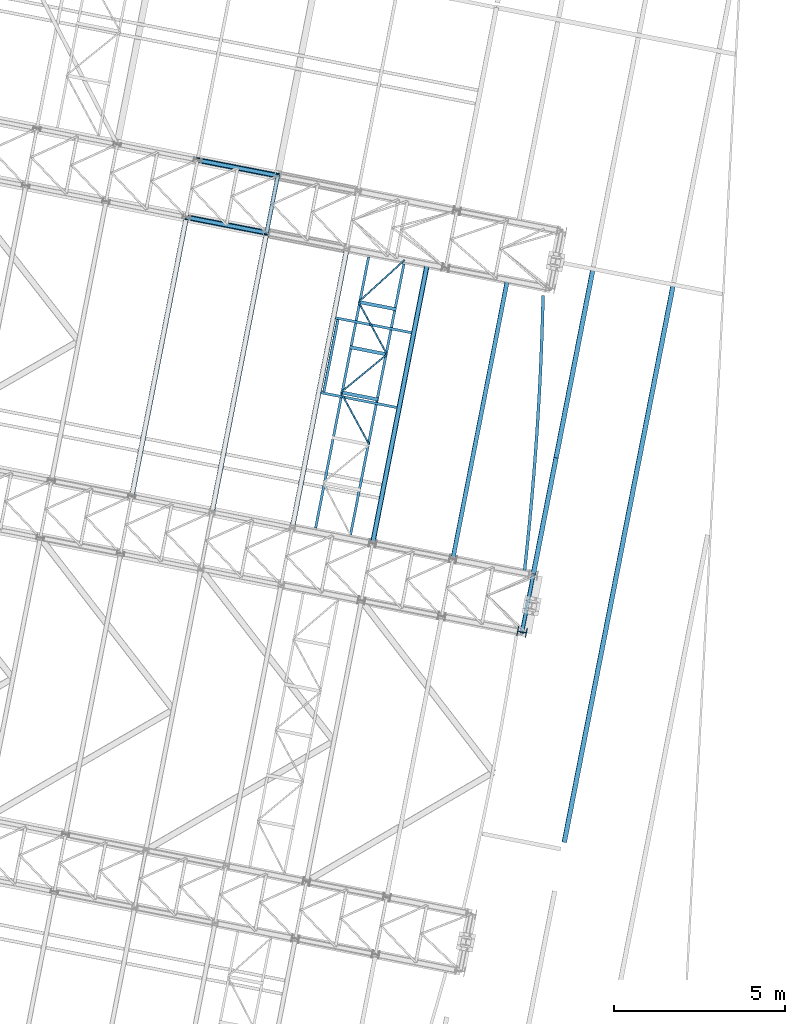
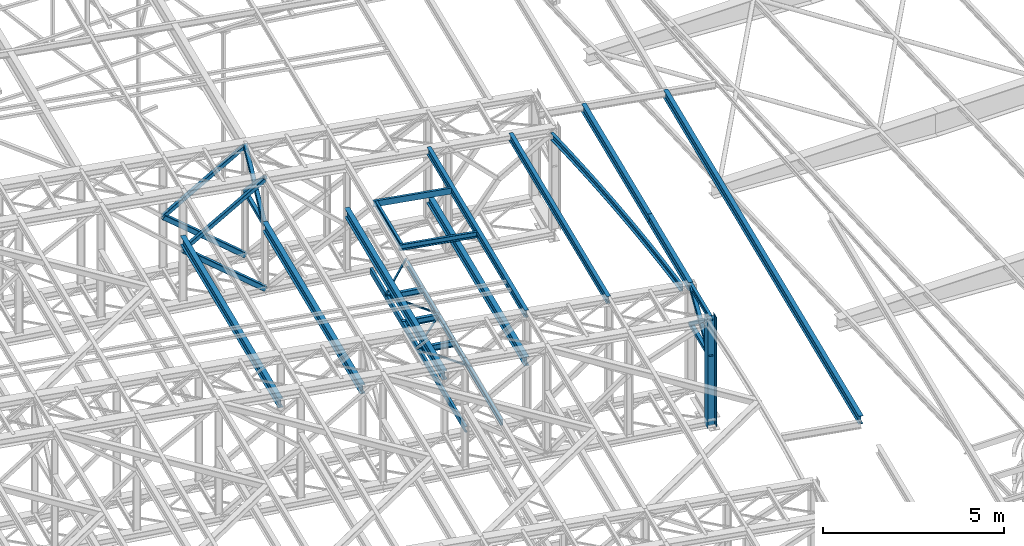
# One storey, part 92 of 215: 26 beams, 8 members, 34 elements without a shape of their own.
"""IFC2X3 building model written with IfcOpenShell, lengths in millimetres."""

from ifc_helpers import new_model, entity, si_unit, frame, origin_with_axes, origin_2d_with_axis, place, context, subcontext, project, spatial, hollow_rectangle, i_section, u_section, extrude, material, type_object, element, aggregate, save


model = new_model("IFC2X3")

# Units and contexts
model_context = context("Model", 3, precision=1e-05, world=origin_with_axes())
body_context = subcontext(model_context, "Body", "Model", "MODEL_VIEW")
ifc_project = project(units=[si_unit("LENGTHUNIT", "METRE", prefix="MILLI"), si_unit("AREAUNIT", "SQUARE_METRE"), si_unit("VOLUMEUNIT", "CUBIC_METRE"), si_unit("MASSUNIT", "GRAM", prefix="KILO"), si_unit("TIMEUNIT", "SECOND"), si_unit("PLANEANGLEUNIT", "RADIAN"), si_unit("SOLIDANGLEUNIT", "STERADIAN"), si_unit("THERMODYNAMICTEMPERATUREUNIT", "DEGREE_CELSIUS"), si_unit("LUMINOUSINTENSITYUNIT", "LUMEN")], contexts=[model_context])

# Site, building, storey
site_placement = place(None, origin_with_axes())
site = spatial("IfcSite", under=ifc_project, at=site_placement, CompositionType="ELEMENT")
building_placement = place(site_placement, origin_with_axes())
building = spatial("IfcBuilding", under=site, at=building_placement, Name="Undefined", CompositionType="ELEMENT")
storey_placement = place(building_placement, origin_with_axes())
storey = spatial("IfcBuildingStorey", under=building, at=storey_placement, Name="Undefined", CompositionType="ELEMENT", Elevation=0.0)

# Assembly, beam
assembly_1_placement = place(storey_placement, origin_with_axes())
assembly_1 = element("IfcElementAssembly", 1, at=assembly_1_placement, inside=storey, Name="Steel Assembly", AssemblyPlace="NOTDEFINED", PredefinedType="RIGID_FRAME")
ifc_material_1 = material(Name="STEEL/S275JR")
beam_type_1 = type_object("IfcBeamType", Name="IPE240", PredefinedType="NOTDEFINED")
beam_1_placement = place(assembly_1_placement, frame((92464.7736029224, 34669.0166630086, 12133.5284038221), z_axis=(0.0304080349965938, -0.00594450399933318, 0.999519891888024), x_axis=(0.191879342079262, 0.981418523405397, 1.00000006478113e-09)))
beam_1 = element("IfcBeam", 2, at=beam_1_placement, type_object=beam_type_1, material=ifc_material_1, ObjectType="IPE240", context=body_context, shape_type="SweptSolid", body=[
    extrude(i_section(OverallWidth=120.0, OverallDepth=240.0, WebThickness=6.199999809, FlangeThickness=9.800000191, FilletRadius=15.0, at=origin_2d_with_axis()), frame((8306.35394615426, -2.30547635042662e-13, -1.81898940354586e-12), z_axis=(-1.0, 0.0, 0.0), x_axis=(-6.93889390390723e-18, -1.0, -3.46944695195361e-18)), (0.0, 0.0, 1.0), 8306.4),
])
aggregate(assembly_1, [beam_1])

assembly_2_placement = place(storey_placement, origin_with_axes())
assembly_2 = element("IfcElementAssembly", 3, at=assembly_2_placement, inside=storey, Name="Steel Assembly", AssemblyPlace="NOTDEFINED", PredefinedType="RIGID_FRAME")
beam_2_placement = place(assembly_2_placement, frame((90120.7257215296, 35127.2574103357, 12207.5658521995), z_axis=(0.0304080349965938, -0.00594450399933318, 0.999519891888024), x_axis=(0.191879342079262, 0.981418523405397, 1.00000006478113e-09)))
beam_2 = element("IfcBeam", 4, at=beam_2_placement, type_object=beam_type_1, material=ifc_material_1, ObjectType="IPE240", context=body_context, shape_type="SweptSolid", body=[
    extrude(i_section(OverallWidth=120.0, OverallDepth=240.0, WebThickness=6.199999809, FlangeThickness=9.800000191, FilletRadius=15.0, at=origin_2d_with_axis()), frame((8306.35394615426, -2.30547635042662e-13, -1.81898940354586e-12), z_axis=(-1.0, 0.0, 0.0), x_axis=(-6.93889390390723e-18, -1.0, -3.46944695195361e-18)), (0.0, 0.0, 1.0), 8306.4),
])
aggregate(assembly_2, [beam_2])

assembly_3_placement = place(storey_placement, origin_with_axes())
assembly_3 = element("IfcElementAssembly", 5, at=assembly_3_placement, inside=storey, Name="Steel Assembly", AssemblyPlace="NOTDEFINED", PredefinedType="RIGID_FRAME")
beam_type_2 = type_object("IfcBeamType", Name="IPE270", PredefinedType="NOTDEFINED")
beam_3_placement = place(assembly_3_placement, frame((95717.9008817921, 26398.0012598187, 11970.3617768862), z_axis=(0.0304080349965938, -0.00594450399933318, 0.999519891888024), x_axis=(0.191856902084618, 0.981422910432851, 8.10000000298011e-08)))
beam_3 = element("IfcBeam", 6, at=beam_3_placement, type_object=beam_type_2, material=ifc_material_1, ObjectType="IPE270", context=body_context, shape_type="SweptSolid", body=[
    extrude(i_section(OverallWidth=135.0, OverallDepth=270.0, WebThickness=6.599999905, FlangeThickness=10.19999981, FilletRadius=15.0, at=origin_2d_with_axis()), frame((16594.88763763, -1.46841138771197e-11, 1.79283458527974e-12), z_axis=(-1.0, 0.0, 0.0), x_axis=(-6.93889390390723e-18, -1.0, -3.46944695195361e-18)), (0.0, 0.0, 1.0), 16594.9),
])
aggregate(assembly_3, [beam_3])

assembly_4_placement = place(storey_placement, origin_with_axes())
assembly_4 = element("IfcElementAssembly", 7, at=assembly_4_placement, inside=storey, Name="Steel Assembly", AssemblyPlace="NOTDEFINED", PredefinedType="RIGID_FRAME")
beam_4_placement = place(assembly_4_placement, frame((94811.4975987775, 34210.2529990498, 12044.3992257007), z_axis=(0.0304080349965938, -0.00594450399933318, 0.999519891888024), x_axis=(0.191859470081235, 0.981422408415534, 0.0)))
beam_4 = element("IfcBeam", 8, at=beam_4_placement, type_object=beam_type_2, material=ifc_material_1, ObjectType="IPE270", context=body_context, shape_type="SweptSolid", body=[
    extrude(i_section(OverallWidth=135.0, OverallDepth=270.0, WebThickness=6.599999905, FlangeThickness=10.19999981, FilletRadius=15.0, at=origin_2d_with_axis()), frame((3479.26394301375, 0.0, 0.0), z_axis=(-1.0, 0.0, 0.0), x_axis=(-6.93889390390723e-18, -1.0, -3.46944695195361e-18)), (0.0, 0.0, 1.0), 3479.3),
])
aggregate(assembly_4, [beam_4])

assembly_5_placement = place(storey_placement, origin_with_axes())
assembly_5 = element("IfcElementAssembly", 9, at=assembly_5_placement, inside=storey, Name="Steel Assembly", AssemblyPlace="NOTDEFINED", PredefinedType="RIGID_FRAME")
beam_5_placement = place(assembly_5_placement, frame((95479.0273205774, 37624.8806002424, 12044.3992256195), z_axis=(0.0304080349965938, -0.00594450399933318, 0.999519891888024), x_axis=(0.191851899087581, 0.98142388844802, 2.39000000165156e-07)))
beam_5 = element("IfcBeam", 10, at=beam_5_placement, type_object=beam_type_2, material=ifc_material_1, ObjectType="IPE270", context=body_context, shape_type="SweptSolid", body=[
    extrude(i_section(OverallWidth=135.0, OverallDepth=270.0, WebThickness=6.599999905, FlangeThickness=10.19999981, FilletRadius=15.0, at=origin_2d_with_axis()), frame((5622.40682280192, 9.98296796440295e-14, -1.81760682979885e-12), z_axis=(-1.0, 0.0, 0.0), x_axis=(-6.93889390390723e-18, -1.0, -3.46944695195361e-18)), (0.0, 0.0, 1.0), 5622.4),
])
aggregate(assembly_5, [beam_5])

assembly_6_placement = place(storey_placement, origin_with_axes())
assembly_6 = element("IfcElementAssembly", 11, at=assembly_6_placement, inside=storey, Name="Steel Assembly", AssemblyPlace="NOTDEFINED", PredefinedType="RIGID_FRAME")
beam_type_3 = type_object("IfcBeamType", PredefinedType="NOTDEFINED")
beam_6_placement = place(assembly_6_placement, frame((87029.9324652651, 44195.0674298513, 10796.000000583), z_axis=(0.981422364268518, -0.191859461052493, -0.000300197000082615), x_axis=(0.191859470081235, 0.981422408415534, 0.0)))
beam_6 = element("IfcBeam", 12, at=beam_6_placement, type_object=beam_type_3, material=ifc_material_1, context=body_context, shape_type="SweptSolid", body=[
    extrude(hollow_rectangle(XDim=120.0, YDim=120.0, WallThickness=5.0, InnerFilletRadius=5.0, OuterFilletRadius=10.0, at=origin_2d_with_axis()), frame((1699.99999941724, 1.81898940354586e-12, 0.0), z_axis=(-1.0, 0.0, 0.0), x_axis=(-6.93889390390723e-18, -1.0, -3.46944695195361e-18)), (0.0, 0.0, 1.0), 1700.0),
])
aggregate(assembly_6, [beam_6])

assembly_7_placement = place(storey_placement, origin_with_axes())
assembly_7 = element("IfcElementAssembly", 13, at=assembly_7_placement, inside=storey, Name="Steel Assembly", AssemblyPlace="NOTDEFINED", PredefinedType="RIGID_FRAME")
beam_7_placement = place(assembly_7_placement, frame((94486.3047201843, 32541.6453840802, 10796.000000571), z_axis=(0.981422364268518, -0.191859461052493, -0.000300197000082615), x_axis=(0.191859470081235, 0.981422408415534, 0.0)))
beam_7 = element("IfcBeam", 14, at=beam_7_placement, type_object=beam_type_3, material=ifc_material_1, context=body_context, shape_type="SweptSolid", body=[
    extrude(hollow_rectangle(XDim=120.0, YDim=120.0, WallThickness=5.0, InnerFilletRadius=5.0, OuterFilletRadius=10.0, at=origin_2d_with_axis()), frame((1699.99999941724, 1.81898940354586e-12, 0.0), z_axis=(-1.0, 0.0, 0.0), x_axis=(-6.93889390390723e-18, -1.0, -3.46944695195361e-18)), (0.0, 0.0, 1.0), 1700.0),
])
aggregate(assembly_7, [beam_7])

assembly_8_placement = place(storey_placement, origin_with_axes())
assembly_8 = element("IfcElementAssembly", 15, at=assembly_8_placement, inside=storey, Name="Steel Assembly", AssemblyPlace="NOTDEFINED", PredefinedType="RIGID_FRAME")
beam_type_4 = type_object("IfcBeamType", PredefinedType="NOTDEFINED")
beam_8_placement = place(assembly_8_placement, frame((89196.8303860117, 39539.664538878, 8705.0), z_axis=(0.0, 0.0, -1.0), x_axis=(0.47673765088779, -0.879045625793105, 0.0)))
beam_8 = element("IfcBeam", 16, at=beam_8_placement, type_object=beam_type_4, material=ifc_material_1, context=body_context, shape_type="SweptSolid", body=[
    extrude(hollow_rectangle(XDim=50.0, YDim=50.0, WallThickness=3.0, InnerFilletRadius=3.0, OuterFilletRadius=6.0, at=origin_2d_with_axis()), frame((1742.75933422754, 0.0, 1.81898940354586e-12), z_axis=(-1.0, 0.0, 0.0), x_axis=(-6.93889390390723e-18, -1.0, -3.46944695195361e-18)), (0.0, 0.0, 1.0), 1742.8),
])
aggregate(assembly_8, [beam_8])

assembly_9_placement = place(storey_placement, origin_with_axes())
assembly_9 = element("IfcElementAssembly", 17, at=assembly_9_placement, inside=storey, Name="Steel Assembly", AssemblyPlace="NOTDEFINED", PredefinedType="RIGID_FRAME")
beam_9_placement = place(assembly_9_placement, frame((90543.5401901868, 40646.5326737359, 8705.0), z_axis=(0.0, 0.0, -1.0), x_axis=(-0.772545523248249, -0.634959380204033, 0.0)))
beam_9 = element("IfcBeam", 18, at=beam_9_placement, type_object=beam_type_4, material=ifc_material_1, context=body_context, shape_type="SweptSolid", body=[
    extrude(hollow_rectangle(XDim=50.0, YDim=50.0, WallThickness=3.0, InnerFilletRadius=3.0, OuterFilletRadius=6.0, at=origin_2d_with_axis()), frame((1743.21093515124, 0.0, 0.0), z_axis=(-1.0, 0.0, 0.0), x_axis=(-6.93889390390723e-18, -1.0, -3.46944695195361e-18)), (0.0, 0.0, 1.0), 1743.2),
])
aggregate(assembly_9, [beam_9])

assembly_10_placement = place(storey_placement, origin_with_axes())
assembly_10 = element("IfcElementAssembly", 19, at=assembly_10_placement, inside=storey, Name="Steel Assembly", AssemblyPlace="NOTDEFINED", PredefinedType="RIGID_FRAME")
beam_10_placement = place(assembly_10_placement, frame((89712.6980049492, 42178.4982678399, 8705.0), z_axis=(0.0, 0.0, -1.0), x_axis=(0.476738917056294, -0.879044939103794, 0.0)))
beam_10 = element("IfcBeam", 20, at=beam_10_placement, type_object=beam_type_4, material=ifc_material_1, context=body_context, shape_type="SweptSolid", body=[
    extrude(hollow_rectangle(XDim=50.0, YDim=50.0, WallThickness=3.0, InnerFilletRadius=3.0, OuterFilletRadius=6.0, at=origin_2d_with_axis()), frame((1742.76140598496, 0.0, 0.0), z_axis=(-1.0, 0.0, 0.0), x_axis=(-6.93889390390723e-18, -1.0, -3.46944695195361e-18)), (0.0, 0.0, 1.0), 1742.8),
])
aggregate(assembly_10, [beam_10])

assembly_11_placement = place(storey_placement, origin_with_axes())
assembly_11 = element("IfcElementAssembly", 21, at=assembly_11_placement, inside=storey, Name="Steel Assembly", AssemblyPlace="NOTDEFINED", PredefinedType="RIGID_FRAME")
beam_11_placement = place(assembly_11_placement, frame((91061.8771984963, 43406.8577655462, 8705.0), z_axis=(0.0, 0.0, -1.0), x_axis=(-0.73943985096372, -0.673222627966969, 0.0)))
beam_11 = element("IfcBeam", 22, at=beam_11_placement, type_object=beam_type_4, material=ifc_material_1, context=body_context, shape_type="SweptSolid", body=[
    extrude(hollow_rectangle(XDim=50.0, YDim=50.0, WallThickness=3.0, InnerFilletRadius=3.0, OuterFilletRadius=6.0, at=origin_2d_with_axis()), frame((1824.59627101341, 0.0, 1.81898940354586e-12), z_axis=(-1.0, 0.0, 0.0), x_axis=(-6.93889390390723e-18, -1.0, -3.46944695195361e-18)), (0.0, 0.0, 1.0), 1824.6),
])
aggregate(assembly_11, [beam_11])

assembly_12_placement = place(storey_placement, origin_with_axes())
assembly_12 = element("IfcElementAssembly", 23, at=assembly_12_placement, inside=storey, Name="Steel Assembly", AssemblyPlace="NOTDEFINED", PredefinedType="RIGID_FRAME")
beam_type_5 = type_object("IfcBeamType", Name="IPE180", PredefinedType="NOTDEFINED")
beam_12_placement = place(assembly_12_placement, frame((94815.6026834551, 34209.4504909996, 12089.3344109517), z_axis=(0.0, 0.0, 1.0), x_axis=(-0.191859508000518, -0.981422401002646, -1.00000033853845e-09)))
beam_12 = element("IfcBeam", 24, at=beam_12_placement, type_object=beam_type_5, material=ifc_material_1, ObjectType="IPE180", context=body_context, shape_type="SweptSolid", body=[
    extrude(i_section(OverallWidth=91.0, OverallDepth=180.0, WebThickness=5.300000191, FlangeThickness=8.0, FilletRadius=9.0, at=origin_2d_with_axis()), frame((1699.99999941724, 1.81898940354586e-12, 0.0), z_axis=(-1.0, 0.0, 0.0), x_axis=(-6.93889390390723e-18, -1.0, -3.46944695195361e-18)), (0.0, 0.0, 1.0), 1700.0),
])
aggregate(assembly_12, [beam_12])

assembly_13_placement = place(storey_placement, origin_with_axes())
assembly_13 = element("IfcElementAssembly", 25, at=assembly_13_placement, inside=storey, Name="Steel Assembly", AssemblyPlace="NOTDEFINED", PredefinedType="RIGID_FRAME")
ifc_material_2 = material(Name="STEEL/S235JR")
beam_type_6 = type_object("IfcBeamType", Name="UPN200", PredefinedType="NOTDEFINED")
beam_13_placement = place(assembly_13_placement, frame((89110.6194647194, 41661.9895352668, 12297.155118531), z_axis=(0.0304080349965938, -0.00594450399933318, 0.999519891888024), x_axis=(-0.19187685493533, -0.98141900966922, -1.21999999765762e-07)))
beam_13 = element("IfcBeam", 26, at=beam_13_placement, type_object=beam_type_6, material=ifc_material_2, ObjectType="UPN200", context=body_context, shape_type="SweptSolid", body=[
    extrude(u_section(Depth=200.0, FlangeWidth=75.0, WebThickness=8.5, FlangeThickness=11.5, FilletRadius=11.5, EdgeRadius=6.0, FlangeSlope=0.0798299857122373, at=origin_2d_with_axis()), frame((2150.01524213469, 1.45109582611845e-11, -1.81736478151208e-12), z_axis=(-1.0, 0.0, 0.0), x_axis=(-6.93889390390723e-18, -1.0, -3.46944695195361e-18)), (0.0, 0.0, 1.0), 2150.0),
])
aggregate(assembly_13, [beam_13])

assembly_14_placement = place(storey_placement, origin_with_axes())
assembly_14 = element("IfcElementAssembly", 27, at=assembly_14_placement, inside=storey, Name="Steel Assembly", AssemblyPlace="NOTDEFINED", PredefinedType="RIGID_FRAME")
beam_14_placement = place(assembly_14_placement, frame((91263.0604896444, 41279.3433122917, 12229.4151626319), z_axis=(0.0304080349965938, -0.00594450399933318, 0.999519891888024), x_axis=(-0.980947274706054, 0.19178753394253, 0.030983641990716)))
beam_14 = element("IfcBeam", 28, at=beam_14_placement, type_object=beam_type_6, material=ifc_material_2, ObjectType="UPN200", context=body_context, shape_type="SweptSolid", body=[
    extrude(u_section(Depth=200.0, FlangeWidth=75.0, WebThickness=8.5, FlangeThickness=11.5, FilletRadius=11.5, EdgeRadius=6.0, FlangeSlope=0.0798299857122373, at=origin_2d_with_axis()), frame((2269.56619159897, -1.00164711038344e-14, -7.87413950570001e-15), z_axis=(-1.0, 0.0, 0.0), x_axis=(-6.93889390390723e-18, -1.0, -3.46944695195361e-18)), (0.0, 0.0, 1.0), 2269.6),
])
aggregate(assembly_14, [beam_14])

assembly_15_placement = place(storey_placement, origin_with_axes())
assembly_15 = element("IfcElementAssembly", 29, at=assembly_15_placement, inside=storey, Name="Steel Assembly", AssemblyPlace="NOTDEFINED", PredefinedType="RIGID_FRAME")
beam_15_placement = place(assembly_15_placement, frame((88609.8028451448, 39530.9733193749, 12299.7346048043), z_axis=(0.0304080349965938, -0.00594450399933318, 0.999519891888024), x_axis=(0.980947274706054, -0.191787533942531, -0.0309836419907153)))
beam_15 = element("IfcBeam", 30, at=beam_15_placement, type_object=beam_type_6, material=ifc_material_2, ObjectType="UPN200", context=body_context, shape_type="SweptSolid", body=[
    extrude(u_section(Depth=200.0, FlangeWidth=75.0, WebThickness=8.5, FlangeThickness=11.5, FilletRadius=11.5, EdgeRadius=6.0, FlangeSlope=0.0798299857122373, at=origin_2d_with_axis()), frame((2269.56619159897, -1.00164711038344e-14, -7.87413950570001e-15), z_axis=(-1.0, 0.0, 0.0), x_axis=(-6.93889390390723e-18, -1.0, -3.46944695195361e-18)), (0.0, 0.0, 1.0), 2269.6),
])
aggregate(assembly_15, [beam_15])

assembly_16_placement = place(storey_placement, origin_with_axes())
assembly_16 = element("IfcElementAssembly", 31, at=assembly_16_placement, inside=storey, Name="Steel Assembly", AssemblyPlace="NOTDEFINED", PredefinedType="RIGID_FRAME")
beam_16_placement = place(assembly_16_placement, frame((90007.4367460947, 43490.7200616785, 8630.00000003358), z_axis=(0.0, 0.0, -1.0), x_axis=(-0.191860814904866, -0.981422145513357, 0.0)))
beam_16 = element("IfcBeam", 32, at=beam_16_placement, type_object=beam_type_6, material=ifc_material_1, ObjectType="UPN200", context=body_context, shape_type="SweptSolid", body=[
    extrude(u_section(Depth=200.0, FlangeWidth=75.0, WebThickness=8.5, FlangeThickness=11.5, FilletRadius=11.5, EdgeRadius=6.0, FlangeSlope=0.0798299857122373, at=origin_2d_with_axis()), frame((8066.3539238149, -1.45519152283669e-11, 0.0), z_axis=(-1.0, 0.0, 0.0), x_axis=(-6.93889390390723e-18, -1.0, -3.46944695195361e-18)), (0.0, 0.0, 1.0), 8066.4),
])
aggregate(assembly_16, [beam_16])

assembly_17_placement = place(storey_placement, origin_with_axes())
assembly_17 = element("IfcElementAssembly", 33, at=assembly_17_placement, inside=storey, Name="Steel Assembly", AssemblyPlace="NOTDEFINED", PredefinedType="RIGID_FRAME")
beam_17_placement = place(assembly_17_placement, frame((89478.2340234499, 35375.1935051525, 8630.00000000009), z_axis=(0.0, 0.0, -1.0), x_axis=(0.193474000916928, 0.981105402578743, 0.0)))
beam_17 = element("IfcBeam", 34, at=beam_17_placement, type_object=beam_type_6, material=ifc_material_1, ObjectType="UPN200", context=body_context, shape_type="SweptSolid", body=[
    extrude(u_section(Depth=200.0, FlangeWidth=75.0, WebThickness=8.5, FlangeThickness=11.5, FilletRadius=11.5, EdgeRadius=6.0, FlangeSlope=0.0798299857122373, at=origin_2d_with_axis()), frame((8066.36484263777, 0.0, 0.0), z_axis=(-1.0, 0.0, 0.0), x_axis=(-6.93889390390723e-18, -1.0, -3.46944695195361e-18)), (0.0, 0.0, 1.0), 8066.4),
])
aggregate(assembly_17, [beam_17])

# Assembly, member
assembly_18_placement = place(storey_placement, origin_with_axes())
assembly_18 = element("IfcElementAssembly", 35, at=assembly_18_placement, inside=storey, Name="Steel Assembly", AssemblyPlace="NOTDEFINED", PredefinedType="RIGID_FRAME")
member_type_1 = type_object("IfcMemberType", PredefinedType="NOTDEFINED")
member_1_placement = place(assembly_18_placement, frame((87356.093563519, 45863.4855236941, 10796.0000007861), z_axis=(0.981461701624211, -0.19165823792662, 0.000219270999915979), x_axis=(-0.140138869039808, -0.716855033203644, 0.682993381194025)))
member_1 = element("IfcMember", 36, at=member_1_placement, type_object=member_type_1, material=ifc_material_1, context=body_context, shape_type="SweptSolid", body=[
    extrude(hollow_rectangle(XDim=120.0, YDim=120.0, WallThickness=5.0, InnerFilletRadius=5.0, OuterFilletRadius=10.0, at=origin_2d_with_axis()), frame((2327.41350452431, -7.27595761418343e-12, -1.06739260704213e-13), z_axis=(-1.0, 0.0, 0.0), x_axis=(-6.93889390390723e-18, -1.0, -3.46944695195361e-18)), (0.0, 0.0, 1.0), 2327.4),
])
aggregate(assembly_18, [member_1])

assembly_19_placement = place(storey_placement, origin_with_axes())
assembly_19 = element("IfcElementAssembly", 37, at=assembly_19_placement, inside=storey, Name="Steel Assembly", AssemblyPlace="NOTDEFINED", PredefinedType="RIGID_FRAME")
member_2_placement = place(assembly_19_placement, frame((87029.9324652651, 44195.0674298513, 10796.000000583), z_axis=(0.981461701624211, -0.19165823792662, -0.000219270999915979), x_axis=(0.140138870001192, 0.716855037006089, 0.682993377005801)))
member_2 = element("IfcMember", 38, at=member_2_placement, type_object=member_type_1, material=ifc_material_1, context=body_context, shape_type="SweptSolid", body=[
    extrude(hollow_rectangle(XDim=120.0, YDim=120.0, WallThickness=5.0, InnerFilletRadius=5.0, OuterFilletRadius=10.0, at=origin_2d_with_axis()), frame((2327.41350452431, -7.27595761418343e-12, -1.06739260704213e-13), z_axis=(-1.0, 0.0, 0.0), x_axis=(-6.93889390390723e-18, -1.0, -3.46944695195361e-18)), (0.0, 0.0, 1.0), 2327.4),
])
aggregate(assembly_19, [member_2])

assembly_20_placement = place(storey_placement, origin_with_axes())
assembly_20 = element("IfcElementAssembly", 39, at=assembly_20_placement, inside=storey, Name="Steel Assembly", AssemblyPlace="NOTDEFINED", PredefinedType="RIGID_FRAME")
member_3_placement = place(assembly_20_placement, frame((94812.4658186527, 34210.0634777308, 10796.0000009211), z_axis=(0.981457237582708, -0.191681072918501, 0.000238916999899001), x_axis=(-0.152693340951056, -0.781075161749645, 0.605480251805928)))
member_3 = element("IfcMember", 40, at=member_3_placement, type_object=member_type_1, material=ifc_material_1, context=body_context, shape_type="SweptSolid", body=[
    extrude(hollow_rectangle(XDim=120.0, YDim=120.0, WallThickness=5.0, InnerFilletRadius=5.0, OuterFilletRadius=10.0, at=origin_2d_with_axis()), frame((2136.05318296857, 7.27595761418343e-12, -1.45865960330521e-11), z_axis=(-1.0, 0.0, 0.0), x_axis=(-6.93889390390723e-18, -1.0, -3.46944695195361e-18)), (0.0, 0.0, 1.0), 2136.1),
])
aggregate(assembly_20, [member_3])

assembly_21_placement = place(storey_placement, origin_with_axes())
assembly_21 = element("IfcElementAssembly", 41, at=assembly_21_placement, inside=storey, Name="Steel Assembly", AssemblyPlace="NOTDEFINED", PredefinedType="RIGID_FRAME")
member_4_placement = place(assembly_21_placement, frame((94486.3047201843, 32541.6453840802, 10796.000000571), z_axis=(0.981457237582473, -0.191681072918455, -0.000238917999897463), x_axis=(0.15269334193976, 0.781075164691848, 0.605480247761123)))
member_4 = element("IfcMember", 42, at=member_4_placement, type_object=member_type_1, material=ifc_material_1, context=body_context, shape_type="SweptSolid", body=[
    extrude(hollow_rectangle(XDim=120.0, YDim=120.0, WallThickness=5.0, InnerFilletRadius=5.0, OuterFilletRadius=10.0, at=origin_2d_with_axis()), frame((2136.05318296857, 7.27595761418343e-12, -1.45865960330521e-11), z_axis=(-1.0, 0.0, 0.0), x_axis=(-6.93889390390723e-18, -1.0, -3.46944695195361e-18)), (0.0, 0.0, 1.0), 2136.1),
])
aggregate(assembly_21, [member_4])

assembly_22_placement = place(storey_placement, origin_with_axes())
assembly_22 = element("IfcElementAssembly", 43, at=assembly_22_placement, inside=storey, Name="Steel Assembly", AssemblyPlace="NOTDEFINED", PredefinedType="RIGID_FRAME")
member_5_placement = place(assembly_22_placement, frame((85009.8541054001, 46322.1547804146, 10487.8287684387), z_axis=(0.597857237183729, -0.116875832035918, -0.793036420243705), x_axis=(0.778303714010845, -0.15215154400212, 0.609174225008491)))
member_5 = element("IfcMember", 44, at=member_5_placement, type_object=member_type_1, material=ifc_material_1, context=body_context, shape_type="SweptSolid", body=[
    extrude(hollow_rectangle(XDim=120.0, YDim=120.0, WallThickness=5.0, InnerFilletRadius=5.0, OuterFilletRadius=10.0, at=origin_2d_with_axis()), frame((3008.71030717514, -1.42604085368763e-15, -6.94192366843814e-12), z_axis=(-1.0, 0.0, 0.0), x_axis=(-6.93889390390723e-18, -1.0, -3.46944695195361e-18)), (0.0, 0.0, 1.0), 3008.7),
])
aggregate(assembly_22, [member_5])

assembly_23_placement = place(storey_placement, origin_with_axes())
assembly_23 = element("IfcElementAssembly", 45, at=assembly_23_placement, inside=storey, Name="Steel Assembly", AssemblyPlace="NOTDEFINED", PredefinedType="RIGID_FRAME")
member_6_placement = place(assembly_23_placement, frame((84683.6930386158, 44653.7366796702, 10487.828768692), z_axis=(0.597857237183729, -0.116875832035918, -0.793036420243705), x_axis=(0.778303714010845, -0.15215154400212, 0.609174225008491)))
member_6 = element("IfcMember", 46, at=member_6_placement, type_object=member_type_1, material=ifc_material_1, context=body_context, shape_type="SweptSolid", body=[
    extrude(hollow_rectangle(XDim=120.0, YDim=120.0, WallThickness=5.0, InnerFilletRadius=5.0, OuterFilletRadius=10.0, at=origin_2d_with_axis()), frame((3008.71030717514, -1.42604085368763e-15, -6.94192366843814e-12), z_axis=(-1.0, 0.0, 0.0), x_axis=(-6.93889390390723e-18, -1.0, -3.46944695195361e-18)), (0.0, 0.0, 1.0), 3008.7),
])
aggregate(assembly_23, [member_6])

# Assembly, beam
assembly_24_placement = place(storey_placement, origin_with_axes())
assembly_24 = element("IfcElementAssembly", 47, at=assembly_24_placement, inside=storey, Name="Steel Assembly", AssemblyPlace="NOTDEFINED", PredefinedType="RIGID_FRAME")
beam_type_7 = type_object("IfcBeamType", Name="IPE300", PredefinedType="NOTDEFINED")
beam_18_placement = place(assembly_24_placement, frame((90124.3791201143, 35126.5434633711, 10605.5499977022), z_axis=(0.0, 0.0, 1.0), x_axis=(0.191879342079262, 0.981418523405397, 1.00000006478113e-09)))
beam_18 = element("IfcBeam", 48, at=beam_18_placement, type_object=beam_type_7, material=ifc_material_1, Name="SUPPORT", ObjectType="IPE300", context=body_context, shape_type="SweptSolid", body=[
    extrude(i_section(OverallWidth=150.0, OverallDepth=300.0, WebThickness=7.099999905, FlangeThickness=10.69999981, FilletRadius=15.0, at=origin_2d_with_axis()), frame((8306.35394615426, -2.30547635042662e-13, -1.81898940354586e-12), z_axis=(-1.0, 0.0, 0.0), x_axis=(-6.93889390390723e-18, -1.0, -3.46944695195361e-18)), (0.0, 0.0, 1.0), 8306.4),
])
aggregate(assembly_24, [beam_18])

assembly_25_placement = place(storey_placement, origin_with_axes())
assembly_25 = element("IfcElementAssembly", 49, at=assembly_25_placement, inside=storey, Name="Steel Assembly", AssemblyPlace="NOTDEFINED", PredefinedType="RIGID_FRAME")
beam_19_placement = place(assembly_25_placement, frame((87780.3312398563, 35584.7842104205, 10679.5800000712), z_axis=(0.0, 0.0, 1.0), x_axis=(0.191879342079262, 0.981418523405397, 1.00000006478113e-09)))
beam_19 = element("IfcBeam", 50, at=beam_19_placement, type_object=beam_type_7, material=ifc_material_1, Name="SUPPORT", ObjectType="IPE300", context=body_context, shape_type="SweptSolid", body=[
    extrude(i_section(OverallWidth=150.0, OverallDepth=300.0, WebThickness=7.099999905, FlangeThickness=10.69999981, FilletRadius=15.0, at=origin_2d_with_axis()), frame((8306.35394615426, -2.30547635042662e-13, -1.81898940354586e-12), z_axis=(-1.0, 0.0, 0.0), x_axis=(-6.93889390390723e-18, -1.0, -3.46944695195361e-18)), (0.0, 0.0, 1.0), 8306.4),
])
aggregate(assembly_25, [beam_19])

assembly_26_placement = place(storey_placement, origin_with_axes())
assembly_26 = element("IfcElementAssembly", 51, at=assembly_26_placement, inside=storey, Name="Steel Assembly", AssemblyPlace="NOTDEFINED", PredefinedType="RIGID_FRAME")
beam_20_placement = place(assembly_26_placement, frame((85436.283359237, 36043.0249573433, 10753.6200000398), z_axis=(0.0, 0.0, 1.0), x_axis=(0.191879342079262, 0.981418523405397, 1.00000006478113e-09)))
beam_20 = element("IfcBeam", 52, at=beam_20_placement, type_object=beam_type_7, material=ifc_material_1, Name="SUPPORT", ObjectType="IPE300", context=body_context, shape_type="SweptSolid", body=[
    extrude(i_section(OverallWidth=150.0, OverallDepth=300.0, WebThickness=7.099999905, FlangeThickness=10.69999981, FilletRadius=15.0, at=origin_2d_with_axis()), frame((8306.35394615426, -2.30547635042662e-13, -1.81898940354586e-12), z_axis=(-1.0, 0.0, 0.0), x_axis=(-6.93889390390723e-18, -1.0, -3.46944695195361e-18)), (0.0, 0.0, 1.0), 8306.4),
])
aggregate(assembly_26, [beam_20])

assembly_27_placement = place(storey_placement, origin_with_axes())
assembly_27 = element("IfcElementAssembly", 53, at=assembly_27_placement, inside=storey, Name="Steel Assembly", AssemblyPlace="NOTDEFINED", PredefinedType="RIGID_FRAME")
beam_21_placement = place(assembly_27_placement, frame((83092.2354795668, 36501.2657039818, 10827.66000008), z_axis=(0.0, 0.0, 1.0), x_axis=(0.191879342079262, 0.981418523405397, 1.00000006478113e-09)))
beam_21 = element("IfcBeam", 54, at=beam_21_placement, type_object=beam_type_7, material=ifc_material_1, Name="SUPPORT", ObjectType="IPE300", context=body_context, shape_type="SweptSolid", body=[
    extrude(i_section(OverallWidth=150.0, OverallDepth=300.0, WebThickness=7.099999905, FlangeThickness=10.69999981, FilletRadius=15.0, at=origin_2d_with_axis()), frame((8306.35394615426, -2.30547635042662e-13, -1.81898940354586e-12), z_axis=(-1.0, 0.0, 0.0), x_axis=(-6.93889390390723e-18, -1.0, -3.46944695195361e-18)), (0.0, 0.0, 1.0), 8306.4),
])
aggregate(assembly_27, [beam_21])

assembly_28_placement = place(storey_placement, origin_with_axes())
assembly_28 = element("IfcElementAssembly", 55, at=assembly_28_placement, inside=storey, Name="Steel Assembly", AssemblyPlace="NOTDEFINED", PredefinedType="RIGID_FRAME")
beam_type_8 = type_object("IfcBeamType", Name="IPE200", PredefinedType="NOTDEFINED")
beam_22_placement = place(assembly_28_placement, frame((90815.5103070485, 41963.1815806884, 8630.00000000005), z_axis=(0.0, 0.0, -1.0), x_axis=(-0.981468202720624, 0.191625068945451, 0.0)))
beam_22 = element("IfcBeam", 56, at=beam_22_placement, type_object=beam_type_8, material=ifc_material_1, ObjectType="IPE200", context=body_context, shape_type="SweptSolid", body=[
    extrude(i_section(OverallWidth=100.0, OverallDepth=200.0, WebThickness=5.599999905, FlangeThickness=8.5, FilletRadius=12.0, at=origin_2d_with_axis()), frame((1123.63528310652, -7.30714475824808e-12, -1.81898940354586e-12), z_axis=(-1.0, 0.0, 0.0), x_axis=(-6.93889390390723e-18, -1.0, -3.46944695195361e-18)), (0.0, 0.0, 1.0), 1123.6),
])
aggregate(assembly_28, [beam_22])

assembly_29_placement = place(storey_placement, origin_with_axes())
assembly_29 = element("IfcElementAssembly", 57, at=assembly_29_placement, inside=storey, Name="Steel Assembly", AssemblyPlace="NOTDEFINED", PredefinedType="RIGID_FRAME")
beam_23_placement = place(assembly_29_placement, frame((90543.5401901977, 40646.5326737288, 8630.00000000005), z_axis=(0.0, 0.0, -1.0), x_axis=(-0.98147285858664, 0.191601220919307, 0.0)))
beam_23 = element("IfcBeam", 58, at=beam_23_placement, type_object=beam_type_8, material=ifc_material_1, ObjectType="IPE200", context=body_context, shape_type="SweptSolid", body=[
    extrude(i_section(OverallWidth=100.0, OverallDepth=200.0, WebThickness=5.599999905, FlangeThickness=8.5, FilletRadius=12.0, at=origin_2d_with_axis()), frame((1109.33031115782, 0.0, 0.0), z_axis=(-1.0, 0.0, 0.0), x_axis=(-6.93889390390723e-18, -1.0, -3.46944695195361e-18)), (0.0, 0.0, 1.0), 1109.3),
])
aggregate(assembly_29, [beam_23])

assembly_30_placement = place(storey_placement, origin_with_axes())
assembly_30 = element("IfcElementAssembly", 59, at=assembly_30_placement, inside=storey, Name="Steel Assembly", AssemblyPlace="NOTDEFINED", PredefinedType="RIGID_FRAME")
beam_24_placement = place(assembly_30_placement, frame((90285.6079773367, 39327.1154973394, 8630.00000000005), z_axis=(0.0, 0.0, -1.0), x_axis=(-0.98147285858664, 0.191601220919307, 0.0)))
beam_24 = element("IfcBeam", 60, at=beam_24_placement, type_object=beam_type_8, material=ifc_material_1, ObjectType="IPE200", context=body_context, shape_type="SweptSolid", body=[
    extrude(i_section(OverallWidth=100.0, OverallDepth=200.0, WebThickness=5.599999905, FlangeThickness=8.5, FilletRadius=12.0, at=origin_2d_with_axis()), frame((1109.33031115782, 0.0, 0.0), z_axis=(-1.0, 0.0, 0.0), x_axis=(-6.93889390390723e-18, -1.0, -3.46944695195361e-18)), (0.0, 0.0, 1.0), 1109.3),
])
aggregate(assembly_30, [beam_24])

# Assembly, member
assembly_31_placement = place(storey_placement, origin_with_axes())
assembly_31 = element("IfcElementAssembly", 61, at=assembly_31_placement, inside=storey, Name="Steel Assembly", AssemblyPlace="NOTDEFINED", PredefinedType="RIGID_FRAME")
member_type_2 = type_object("IfcMemberType", PredefinedType="NOTDEFINED")
member_7_placement = place(assembly_31_placement, frame((87358.1150245611, 45864.3851995379, 8655.00000001144), z_axis=(-0.597919313208457, 0.116557844040636, -0.793036420276475), x_axis=(-0.778384530842262, 0.151737555969251, 0.609174224876554)))
member_7 = element("IfcMember", 62, at=member_7_placement, type_object=member_type_2, material=ifc_material_1, context=body_context, shape_type="SweptSolid", body=[
    extrude(hollow_rectangle(XDim=160.0, YDim=160.0, WallThickness=8.0, InnerFilletRadius=12.0, OuterFilletRadius=20.0, at=origin_2d_with_axis()), frame((3008.71030717514, -1.42604085368763e-15, -6.94192366843814e-12), z_axis=(-1.0, 0.0, 0.0), x_axis=(-6.93889390390723e-18, -1.0, -3.46944695195361e-18)), (0.0, 0.0, 1.0), 3008.7),
])
aggregate(assembly_31, [member_7])

assembly_32_placement = place(storey_placement, origin_with_axes())
assembly_32 = element("IfcElementAssembly", 63, at=assembly_32_placement, inside=storey, Name="Steel Assembly", AssemblyPlace="NOTDEFINED", PredefinedType="RIGID_FRAME")
member_8_placement = place(assembly_32_placement, frame((87032.8413574951, 44195.7938649688, 8655.00000001145), z_axis=(-0.597919313208457, 0.116557844040636, -0.793036420276475), x_axis=(-0.778384530842262, 0.151737555969251, 0.609174224876554)))
member_8 = element("IfcMember", 64, at=member_8_placement, type_object=member_type_2, material=ifc_material_1, context=body_context, shape_type="SweptSolid", body=[
    extrude(hollow_rectangle(XDim=160.0, YDim=160.0, WallThickness=8.0, InnerFilletRadius=12.0, OuterFilletRadius=20.0, at=origin_2d_with_axis()), frame((3008.71030717514, -1.42604085368763e-15, -6.94192366843814e-12), z_axis=(-1.0, 0.0, 0.0), x_axis=(-6.93889390390723e-18, -1.0, -3.46944695195361e-18)), (0.0, 0.0, 1.0), 3008.7),
])
aggregate(assembly_32, [member_8])

# Assembly, beam
assembly_33_placement = place(storey_placement, origin_with_axes())
assembly_33 = element("IfcElementAssembly", 65, at=assembly_33_placement, inside=storey, Name="Steel Assembly", AssemblyPlace="NOTDEFINED", PredefinedType="RIGID_FRAME")
beam_type_9 = type_object("IfcBeamType", Name="UPE240", PredefinedType="NOTDEFINED")
beam_25_placement = place(assembly_33_placement, frame((94550.7152662949, 34257.5638276614, 12058.024603923), z_axis=(-0.00031492800007397, 1.98850000057477e-05, -0.99999995021247), x_axis=(0.0678163469679136, 0.997697821527953, -1.5179999992627e-06)))
beam_25 = element("IfcBeam", 66, at=beam_25_placement, type_object=beam_type_9, material=ifc_material_1, ObjectType="UPE240", context=body_context, shape_type="SweptSolid", body=[
    entity("IfcRevolvedAreaSolid", entity("IfcUShapeProfileDef", "AREA", None, entity("IfcAxis2Placement2D", entity("IfcCartesianPoint", [0.0, 0.0]), entity("IfcDirection", [1.0, 0.0])), 240.0, 90.0, 7.0, 12.5, 15.0), entity("IfcAxis2Placement3D", entity("IfcCartesianPoint", [8125.93370684015, 5.908282455748e-14, -8.60366697112235e-18]), entity("IfcDirection", [-0.998979465690623, 0.0451666594788514, 1.05771065133807e-21]), entity("IfcDirection", [-0.0451666594788514, -0.998979465690623, 4.78220608700036e-23])), entity("IfcAxis1Placement", entity("IfcCartesianPoint", [89955.0, 0.0, 0.0]), entity("IfcDirection", [0.0, 1.0, 0.0])), 0.0903640609244546),
])
aggregate(assembly_33, [beam_25])

assembly_34_placement = place(storey_placement, origin_with_axes())
assembly_34 = element("IfcElementAssembly", 67, at=assembly_34_placement, inside=storey, Name="Steel Assembly", AssemblyPlace="NOTDEFINED", PredefinedType="RIGID_FRAME")
beam_type_10 = type_object("IfcBeamType", Name="HEA280", PredefinedType="NOTDEFINED")
beam_26_placement = place(assembly_34_placement, frame((94486.3096304778, 32541.6446639996, 12178.0104060162), z_axis=(0.981422409205525, -0.19185946604018, 1.89999991602007e-08), x_axis=(0.0, 0.0, -1.0)))
beam_26 = element("IfcBeam", 68, at=beam_26_placement, type_object=beam_type_10, material=ifc_material_1, Name="MONTANT", ObjectType="HEA280", context=body_context, shape_type="SweptSolid", body=[
    extrude(i_section(OverallWidth=280.0, OverallDepth=270.0, WebThickness=8.0, FlangeThickness=13.0, FilletRadius=24.0, at=origin_2d_with_axis()), frame((3678.01040601614, 0.0, 0.0), z_axis=(-1.0, 0.0, 0.0), x_axis=(-6.93889390390723e-18, -1.0, -3.46944695195361e-18)), (0.0, 0.0, 1.0), 3678.0),
])
aggregate(assembly_34, [beam_26])

save(model, "model.ifc")
